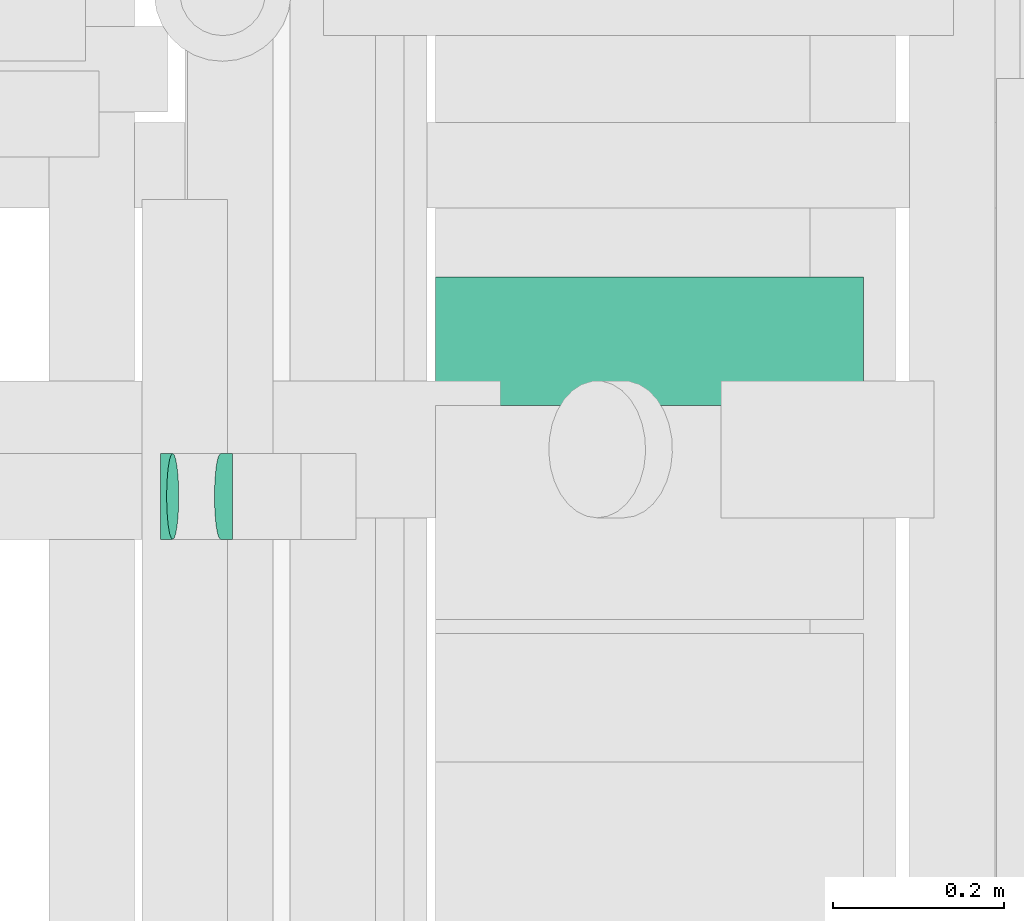
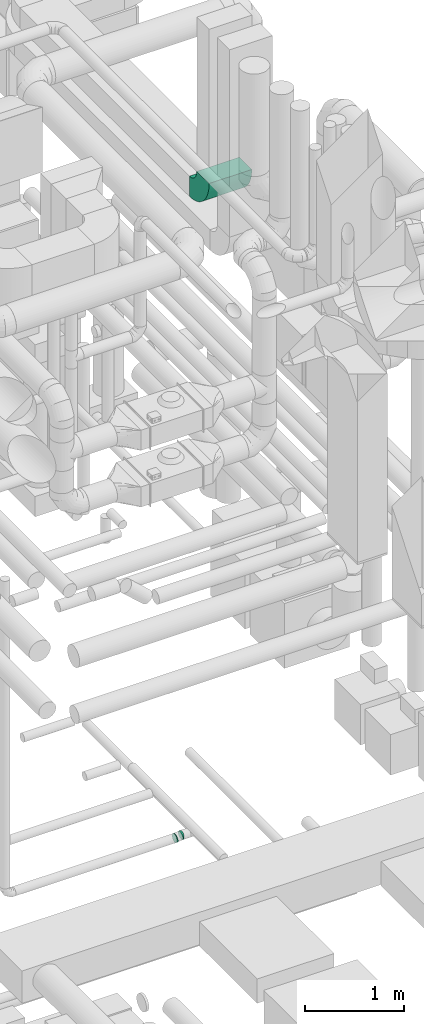
# One storey, part 304 of 337: 3 flow fittings.
"""IFC2X3 building model written with IfcOpenShell, lengths in millimetres."""

from ifc_helpers import new_model, entity, si_unit, converted_unit, derived_unit, direction, frame, frame_2d, origin, place, context, subcontext, project, spatial, polyline, circle_curve, parameter, trimmed, segment, composite_curve, outline, extrude, faceted_brep, source, transform, mapped, material, type_object, type_shapes, element, save


model = new_model("IFC2X3")

# Units and contexts
model_context = context("Model", 3, precision=0.01, world=origin(), true_north=direction((6.12303176911189e-17, 1.0)))
body_context = subcontext(model_context, "Body", "Model", "MODEL_VIEW")
ifc_project = project(units=[si_unit("LENGTHUNIT", "METRE", prefix="MILLI"), si_unit("AREAUNIT", "SQUARE_METRE"), si_unit("VOLUMEUNIT", "CUBIC_METRE"), converted_unit("PLANEANGLEUNIT", "DEGREE", entity("IfcRatioMeasure", 0.0174532925199433), si_unit("PLANEANGLEUNIT", "RADIAN"), dimensions=[0, 0, 0, 0, 0, 0, 0]), si_unit("MASSUNIT", "GRAM", prefix="KILO"), derived_unit("MASSDENSITYUNIT", [(si_unit("MASSUNIT", "GRAM", prefix="KILO"), 1), (si_unit("LENGTHUNIT", "METRE"), -3)]), derived_unit("MOMENTOFINERTIAUNIT", [(si_unit("LENGTHUNIT", "METRE"), 4)]), si_unit("TIMEUNIT", "SECOND"), si_unit("FREQUENCYUNIT", "HERTZ"), si_unit("THERMODYNAMICTEMPERATUREUNIT", "DEGREE_CELSIUS"), derived_unit("THERMALTRANSMITTANCEUNIT", [(si_unit("MASSUNIT", "GRAM", prefix="KILO"), 1), (si_unit("THERMODYNAMICTEMPERATUREUNIT", "KELVIN"), -1), (si_unit("TIMEUNIT", "SECOND"), -3)]), derived_unit("VOLUMETRICFLOWRATEUNIT", [(si_unit("LENGTHUNIT", "METRE"), 3), (si_unit("TIMEUNIT", "SECOND"), -1)]), derived_unit("MASSFLOWRATEUNIT", [(si_unit("MASSUNIT", "GRAM", prefix="KILO"), 1), (si_unit("TIMEUNIT", "SECOND"), -1)]), derived_unit("ROTATIONALFREQUENCYUNIT", [(si_unit("TIMEUNIT", "SECOND"), -1)]), si_unit("ELECTRICCURRENTUNIT", "AMPERE"), si_unit("ELECTRICVOLTAGEUNIT", "VOLT"), si_unit("POWERUNIT", "WATT"), si_unit("FORCEUNIT", "NEWTON", prefix="KILO"), si_unit("ILLUMINANCEUNIT", "LUX"), si_unit("LUMINOUSFLUXUNIT", "LUMEN"), si_unit("LUMINOUSINTENSITYUNIT", "CANDELA"), derived_unit("USERDEFINED", [(si_unit("MASSUNIT", "GRAM", prefix="KILO"), -1), (si_unit("LENGTHUNIT", "METRE"), -2), (si_unit("TIMEUNIT", "SECOND"), 3), (si_unit("LUMINOUSFLUXUNIT", "LUMEN"), 1)]), derived_unit("LINEARVELOCITYUNIT", [(si_unit("LENGTHUNIT", "METRE"), 1), (si_unit("TIMEUNIT", "SECOND"), -1)]), si_unit("PRESSUREUNIT", "PASCAL"), derived_unit("USERDEFINED", [(si_unit("LENGTHUNIT", "METRE"), -2), (si_unit("MASSUNIT", "GRAM", prefix="KILO"), 1), (si_unit("TIMEUNIT", "SECOND"), -2)]), derived_unit("LINEARFORCEUNIT", [(si_unit("MASSUNIT", "GRAM", prefix="KILO"), 1), (si_unit("LENGTHUNIT", "METRE"), 1), (si_unit("TIMEUNIT", "SECOND"), -2), (si_unit("LENGTHUNIT", "METRE"), -1)]), derived_unit("PLANARFORCEUNIT", [(si_unit("MASSUNIT", "GRAM", prefix="KILO"), 1), (si_unit("LENGTHUNIT", "METRE"), 1), (si_unit("TIMEUNIT", "SECOND"), -2), (si_unit("LENGTHUNIT", "METRE"), -2)])], contexts=[model_context])

# Site, building, storey
site_placement = place(None, origin())
site = spatial("IfcSite", under=ifc_project, at=site_placement, CompositionType="ELEMENT")
building_placement = place(site_placement, origin())
building = spatial("IfcBuilding", under=site, at=building_placement, CompositionType="ELEMENT")
storey_placement = place(building_placement, origin())
storey = spatial("IfcBuildingStorey", under=building, at=storey_placement, CompositionType="ELEMENT", Elevation=0.0)

# Flow fittings
ifc_material = material()
duct_fitting_type_1 = type_object("IfcDuctFittingType", PredefinedType="NOTDEFINED", material=ifc_material)
shared_shape_1 = source(origin(), body_context, "Body", "Brep", [
    faceted_brep([(-7.11, 0.0, -50.0), (-7.11, -12.94, -48.3), (-7.11, -25.0, -43.3), (-7.11, -35.36, -35.36), (-7.11, -43.3, -25.0), (-7.11, -48.3, -12.94), (-7.11, -50.0, 0.0), (-7.11, -48.3, 12.94), (-7.11, -43.3, 25.0), (-7.11, -35.36, 35.36), (-7.11, -25.0, 43.3), (-7.11, -12.94, 48.3), (-7.11, 0.0, 50.0), (-7.11, 12.94, 48.3), (-7.11, 25.0, 43.3), (-7.11, 35.36, 35.36), (-7.11, 43.3, 25.0), (-7.11, 48.3, 12.94), (-7.11, 50.0, 0.0), (-7.11, 48.3, -12.94), (-7.11, 43.3, -25.0), (-7.11, 35.36, -35.36), (-7.11, 25.0, -43.3), (-7.11, 12.94, -48.3), (-0.92, 12.94, 48.3), (-1.78, 25.0, 43.3), (0.0, 0.0, 50.0), (-2.51, 35.36, 35.36), (-3.43, 48.3, 12.94), (-3.55, 50.0, 0.0), (-3.08, 43.3, 25.0), (-3.08, 43.3, -25.0), (-2.51, 35.36, -35.36), (-3.43, 48.3, -12.94), (-0.92, 12.94, -48.3), (0.0, 0.0, -50.0), (-1.78, 25.0, -43.3), (0.92, -12.94, -48.3), (1.78, -25.0, -43.3), (2.51, -35.36, -35.36), (3.08, -43.3, -25.0), (3.43, -48.3, -12.94), (3.55, -50.0, 0.0), (3.43, -48.3, 12.94), (3.08, -43.3, 25.0), (2.51, -35.36, 35.36), (1.78, -25.0, 43.3), (0.92, -12.94, 48.3), (7.04, 1.01, 50.0), (5.21, 13.82, 48.3), (3.5, 25.75, 43.3), (2.04, 36.01, 35.36), (0.91, 43.87, 25.0), (0.21, 48.82, 12.94), (-0.04, 50.5, 0.0), (0.21, 48.82, -12.94), (0.91, 43.87, -25.0), (2.04, 36.01, -35.36), (3.5, 25.75, -43.3), (5.21, 13.82, -48.3), (7.04, 1.01, -50.0), (8.87, -11.81, -48.3), (10.57, -23.74, -43.3), (12.04, -33.99, -35.36), (13.16, -41.86, -25.0), (13.87, -46.81, -12.94), (14.11, -48.49, 0.0), (13.87, -46.81, 12.94), (13.16, -41.86, 25.0), (12.04, -33.99, 35.36), (10.57, -23.74, 43.3), (8.87, -11.81, 48.3)], [[[0, 1, 2, 3, 4, 5, 6, 7, 8, 9, 10, 11, 12, 13, 14, 15, 16, 17, 18, 19, 20, 21, 22, 23]], [[24, 25, 14, 13]], [[26, 24, 13, 12]], [[14, 25, 27, 15]], [[28, 29, 18, 17]], [[30, 28, 17, 16]], [[15, 27, 30, 16]], [[20, 31, 32, 21]], [[33, 31, 20, 19]], [[18, 29, 33, 19]], [[34, 35, 0, 23]], [[36, 34, 23, 22]], [[32, 36, 22, 21]], [[2, 1, 37, 38]], [[3, 2, 38, 39]], [[0, 35, 37, 1]], [[5, 4, 40, 41]], [[6, 5, 41, 42]], [[39, 40, 4, 3]], [[6, 42, 43, 7]], [[7, 43, 44, 8]], [[8, 44, 45, 9]], [[10, 46, 47, 11]], [[11, 47, 26, 12]], [[9, 45, 46, 10]], [[24, 26, 48, 49]], [[25, 24, 49, 50]], [[27, 25, 50, 51]], [[28, 30, 52, 53]], [[29, 28, 53, 54]], [[27, 51, 52, 30]], [[29, 54, 55, 33]], [[33, 55, 56, 31]], [[31, 56, 57, 32]], [[36, 58, 59, 34]], [[34, 59, 60, 35]], [[36, 32, 57, 58]], [[35, 60, 61, 37]], [[37, 61, 62, 38]], [[38, 62, 63, 39]], [[40, 64, 65, 41]], [[41, 65, 66, 42]], [[39, 63, 64, 40]], [[43, 42, 66, 67]], [[44, 43, 67, 68]], [[45, 44, 68, 69]], [[47, 46, 70, 71]], [[26, 47, 71, 48]], [[69, 70, 46, 45]], [[59, 58, 57, 56, 55, 54, 53, 52, 51, 50, 49, 48, 71, 70, 69, 68, 67, 66, 65, 64, 63, 62, 61, 60]]]),
])
type_shapes(duct_fitting_type_1, [shared_shape_1])
for number, where, z_axis, x_axis in (
    (1, (70663.72, 11168.54, 27360.0), (0.0, -1.0, 0.0), (-1.0, 0.0, 0.0)),
    (2, (70593.72, 11168.54, 27350.0), (0.0, 1.0, 0.0), (-0.989949425325961, 0.0, -0.141421834582923)),
):
    element("IfcFlowFitting", number, at=place(storey_placement, frame(where, z_axis=z_axis, x_axis=x_axis)), inside=storey, type_object=duct_fitting_type_1, material=ifc_material, context=body_context, shape_type="MappedRepresentation", body=[
        mapped(shared_shape_1, transform((0.0, 0.0, 0.0), scale=1.0)),
    ])
duct_fitting_type_2 = type_object("IfcDuctFittingType", PredefinedType="NOTDEFINED", material=ifc_material)
shared_shape_2 = source(origin(), body_context, "Body", "SweptSolid", [
    extrude(outline(composite_curve([segment(polyline([(-262.5, -137.5), (-12.5, -137.5)]), True, "CONTINUOUS"), segment(trimmed(circle_curve(frame_2d((137.5, -137.5), x_axis=(0.0, 1.0)), 150.0), [parameter(0.0)], [parameter(90.0000000000001)], True, "PARAMETER"), False, "CONTINUOUS"), segment(polyline([(137.5, 12.5), (137.5, 262.5)]), True, "CONTINUOUS"), segment(trimmed(circle_curve(frame_2d((137.5, -137.5), x_axis=(0.0, 1.0)), 400.0), [parameter(0.0)], [parameter(90.0000000000001)], True, "PARAMETER"), True, "CONTINUOUS")], self_intersect=False)), frame((-137.5, 137.5, -250.0), z_axis=(0.0, 0.0, 1.0), x_axis=(-1.0, 0.0, 0.0)), (0.0, 0.0, 1.0), 500.0),
])
type_shapes(duct_fitting_type_2, [shared_shape_2])
flow_fitting_placement = place(storey_placement, frame((71157.48, 11150.0, 35135.0), z_axis=(-1.0, 0.0, 0.0), x_axis=(0.0, -1.0, 0.0)))
element("IfcFlowFitting", 3, at=flow_fitting_placement, inside=storey, type_object=duct_fitting_type_2, material=ifc_material, context=body_context, shape_type="MappedRepresentation", body=[
    mapped(shared_shape_2, transform((0.0, 0.0, 0.0), scale=1.0)),
])

save(model, "model.ifc")
